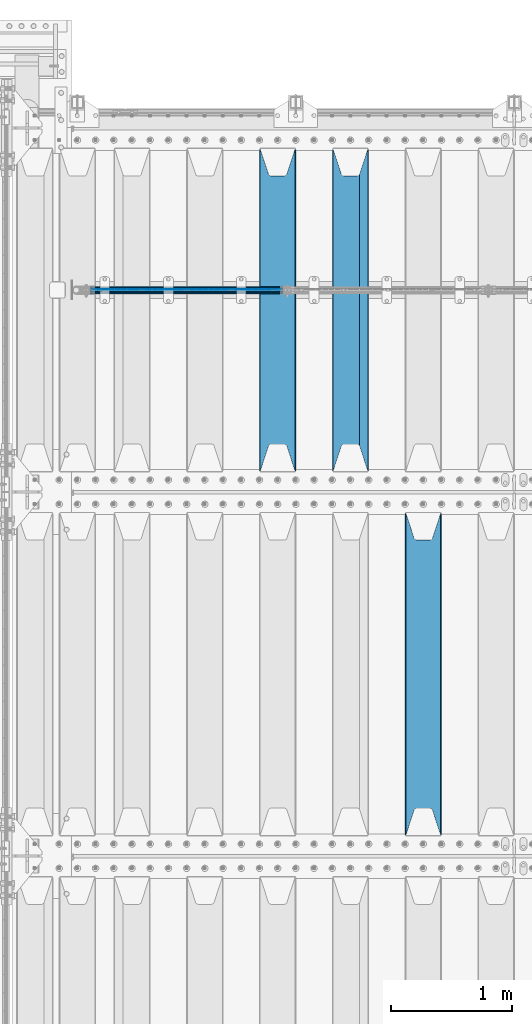
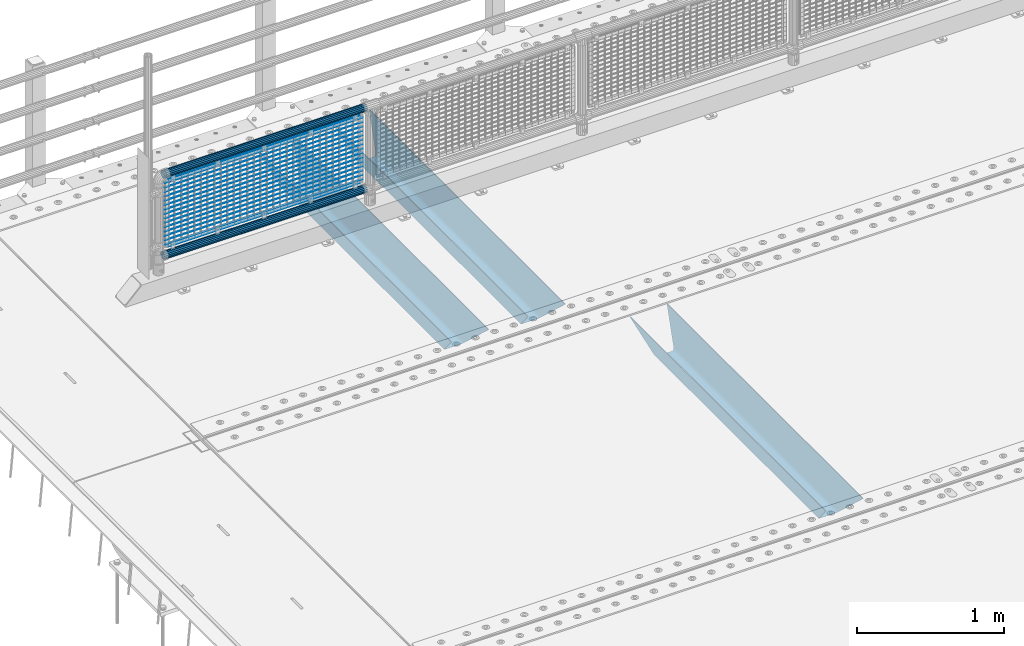
# One storey, part 114 of 240: 22 beams.
"""IFC2X3 building model written with IfcOpenShell, lengths in millimetres."""

from ifc_helpers import new_model, si_unit, frame, origin_with_axes, place, context, subcontext, project, spatial, faceted_brep, material, type_object, element, save


model = new_model("IFC2X3")

# Units and contexts
model_context = context("Model", 3, precision=1e-05, world=origin_with_axes())
body_context = subcontext(model_context, "Body", "Model", "MODEL_VIEW")
ifc_project = project(units=[si_unit("LENGTHUNIT", "METRE", prefix="MILLI"), si_unit("AREAUNIT", "SQUARE_METRE"), si_unit("VOLUMEUNIT", "CUBIC_METRE"), si_unit("MASSUNIT", "GRAM", prefix="KILO"), si_unit("TIMEUNIT", "SECOND"), si_unit("PLANEANGLEUNIT", "RADIAN"), si_unit("SOLIDANGLEUNIT", "STERADIAN"), si_unit("THERMODYNAMICTEMPERATUREUNIT", "DEGREE_CELSIUS"), si_unit("LUMINOUSINTENSITYUNIT", "LUMEN")], contexts=[model_context])

# Site, building, storey
site_placement = place(None, origin_with_axes())
site = spatial("IfcSite", under=ifc_project, at=site_placement, CompositionType="ELEMENT")
building_placement = place(site_placement, origin_with_axes())
building = spatial("IfcBuilding", under=site, at=building_placement, Name="Standard", CompositionType="ELEMENT")
storey_placement = place(building_placement, origin_with_axes())
storey = spatial("IfcBuildingStorey", under=building, at=storey_placement, Name="Undefined", CompositionType="ELEMENT", Elevation=0.0)

# Beams
ifc_material_1 = material(Name="STEEL/S355N")
beam_type_1 = type_object("IfcBeamType", PredefinedType="NOTDEFINED")
beam_1_placement = place(storey_placement, frame((45850.0, 30175.0, -115.0), z_axis=(0.0, 0.0, 1.0), x_axis=(0.0, 1.0, 0.0)))
element("IfcBeam", 1, at=beam_1_placement, inside=storey, type_object=beam_type_1, material=ifc_material_1, context=body_context, shape_type="Brep", body=[
    faceted_brep([(0.0, 150.0, 115.0), (0.0, 143.690000000002, 115.0), (2650.00000000297, 143.690000000002, 115.0), (2650.00000000297, 150.0, 115.0), (2650.00000000297, 142.059565218406, 110.000000003094), (2650.00000000297, 148.369565218403, 110.000000003094), (2441.90079219209, -80.1103600731149, -98.0992078077845), (2437.7588105432, -77.5672621345584, -102.241189456673), (2434.06523489747, -74.4080125315522, -105.934765102404), (2430.9108609509, -70.7102721255724, -109.089139048974), (2428.37322971128, -66.5649389910031, -111.626770288588), (2426.51472138055, -62.0739139532889, -113.485278619323), (2425.38102192092, -57.3475956567636, -114.618978078955), (2424.99999999987, -52.5021667386536, -115.0), (2424.99999999987, 52.5021667386536, -115.0), (2425.38102192092, 57.3475956567636, -114.618978078955), (2426.51472138055, 62.0739139532889, -113.485278619323), (2428.37322971128, 66.5649389910031, -111.626770288588), (2430.9108609509, 70.7102721255724, -109.089139048974), (2434.06523489747, 74.4080125315522, -105.934765102404), (2437.7588105432, 77.5672621345584, -102.241189456673), (2441.90079219209, 80.1103600731149, -98.0992078077846), (2446.38936140512, 81.9747917625791, -93.6106385947584), (2448.2494850041, 76.2713538057287, -91.7505149957729), (2444.62967112263, 74.76777986261, -95.3703288772456), (2441.28936334127, 72.7168944282894, -98.710636658607), (2438.31067330439, 70.1691124903809, -101.689326695487), (2435.76682334748, 67.1870637758839, -104.233176652398), (2433.72034654134, 63.8440531834931, -106.279653458539), (2432.22154950042, 60.2222587982324, -107.778450499454), (2431.30727574265, 56.4107117849126, -108.692724257221), (2430.99999999987, 52.5031078186876, -109.0), (2430.99999999987, -52.5031078186876, -109.0), (2431.30727574265, -56.4107117849126, -108.692724257221), (2432.22154950042, -60.2222587982324, -107.778450499454), (2433.72034654134, -63.8440531834931, -106.279653458539), (2435.76682334748, -67.1870637758839, -104.233176652398), (2438.31067330439, -70.1691124903809, -101.689326695487), (2441.28936334127, -72.7168944282894, -98.7106366586071), (2444.62967112263, -74.76777986261, -95.3703288772457), (2448.2494850041, -76.2713538057287, -91.7505149957729), (2650.00000000297, -142.059565218406, 110.000000003094), (2650.00000000297, -148.369565218403, 110.000000003094), (2446.38936140512, -81.9747917625791, -93.6106385947584), (2650.00000000297, -143.690000000002, 115.0), (2650.00000000297, -150.0, 115.0), (0.0, -143.690000000002, 115.0), (0.0, -150.0, 115.0), (0.0, -148.369565218258, 110.000000002667), (203.610638597427, -81.9747917625791, -93.6106385947584), (208.09920781045, -80.1103600731149, -98.0992078077845), (212.241189459342, -77.5672621345584, -102.241189456673), (215.93476510507, -74.4080125315522, -105.934765102404), (219.089139051641, -70.7102721255724, -109.089139048974), (221.626770291256, -66.5649389910031, -111.626770288588), (223.485278621989, -62.0739139532889, -113.485278619323), (224.618978081624, -57.3475956567636, -114.618978078955), (225.000000002663, -52.5021667386536, -115.0), (225.000000002663, 52.5021667386536, -115.0), (224.618978081624, 57.3475956567636, -114.618978078955), (223.485278621989, 62.0739139532889, -113.485278619323), (221.626770291256, 66.5649389910031, -111.626770288588), (219.089139051641, 70.7102721255724, -109.089139048974), (215.93476510507, 74.4080125315522, -105.934765102404), (212.241189459342, 77.5672621345584, -102.241189456673), (208.09920781045, 80.1103600731149, -98.0992078077846), (203.610638597427, 81.9747917625791, -93.6106385947584), (0.0, 148.369565218258, 110.000000002667), (0.0, 142.05956521826, 110.000000002667), (201.750514998439, 76.2713538057287, -91.7505149957729), (205.370328879908, 74.76777986261, -95.3703288772456), (208.710636661275, 72.7168944282894, -98.710636658607), (211.689326698153, 70.1691124903809, -101.689326695487), (214.233176655063, 67.1870637758839, -104.233176652398), (216.279653461206, 63.8440531834931, -106.279653458539), (217.778450502123, 60.2222587982324, -107.778450499454), (218.692724259887, 56.4107117849126, -108.692724257221), (219.000000002667, 52.5031078186876, -109.0), (219.000000002667, -52.5031078186876, -109.0), (218.692724259887, -56.4107117849126, -108.692724257221), (217.778450502123, -60.2222587982324, -107.778450499454), (216.279653461206, -63.8440531834931, -106.279653458539), (214.233176655063, -67.1870637758839, -104.233176652398), (211.689326698153, -70.1691124903809, -101.689326695487), (208.710636661275, -72.7168944282894, -98.7106366586071), (205.370328879915, -74.76777986261, -95.3703288772457), (201.750514998439, -76.2713538057287, -91.7505149957729), (0.0, -142.05956521826, 110.000000002667)], [[[0, 1, 2, 3]], [[3, 2, 4, 5]], [[6, 7, 8, 9, 10, 11, 12, 13, 14, 15, 16, 17, 18, 19, 20, 21, 22, 5, 4, 23, 24, 25, 26, 27, 28, 29, 30, 31, 32, 33, 34, 35, 36, 37, 38, 39, 40, 41, 42, 43]], [[44, 45, 42, 41]], [[46, 47, 45, 44]], [[43, 42, 45, 47, 48, 49]], [[6, 43, 49, 50]], [[7, 6, 50, 51]], [[8, 7, 51, 52]], [[9, 8, 52, 53]], [[10, 9, 53, 54]], [[11, 10, 54, 55]], [[12, 11, 55, 56]], [[13, 12, 56, 57]], [[14, 13, 57, 58]], [[15, 14, 58, 59]], [[16, 15, 59, 60]], [[17, 16, 60, 61]], [[18, 17, 61, 62]], [[19, 18, 62, 63]], [[20, 19, 63, 64]], [[21, 20, 64, 65]], [[22, 21, 65, 66]], [[0, 3, 5, 22, 66, 67]], [[1, 0, 67, 68]], [[23, 4, 2, 1, 68, 69]], [[24, 23, 69, 70]], [[25, 24, 70, 71]], [[26, 25, 71, 72]], [[27, 26, 72, 73]], [[28, 27, 73, 74]], [[29, 28, 74, 75]], [[30, 29, 75, 76]], [[31, 30, 76, 77]], [[32, 31, 77, 78]], [[33, 32, 78, 79]], [[34, 33, 79, 80]], [[35, 34, 80, 81]], [[36, 35, 81, 82]], [[37, 36, 82, 83]], [[38, 37, 83, 84]], [[39, 38, 84, 85]], [[40, 39, 85, 86]], [[46, 44, 41, 40, 86, 87]], [[47, 46, 87, 48]], [[86, 85, 84, 83, 82, 81, 80, 79, 78, 77, 76, 75, 74, 73, 72, 71, 70, 69, 68, 67, 66, 65, 64, 63, 62, 61, 60, 59, 58, 57, 56, 55, 54, 53, 52, 51, 50, 49, 48, 87]]]),
])
beam_2_placement = place(storey_placement, frame((45250.0, 33175.0, -115.0), z_axis=(0.0, 0.0, 1.0), x_axis=(0.0, 1.0, 0.0)))
element("IfcBeam", 2, at=beam_2_placement, inside=storey, type_object=beam_type_1, material=ifc_material_1, context=body_context, shape_type="Brep", body=[
    faceted_brep([(0.0, 150.0, 115.0), (0.0, 143.690000000002, 115.0), (2650.00000000297, 143.690000000002, 115.0), (2650.00000000297, 150.0, 115.0), (2650.00000000297, 142.059565218406, 110.000000003094), (2650.00000000297, 148.369565218403, 110.000000003094), (2441.90079219209, -80.1103600731149, -98.0992078077845), (2437.7588105432, -77.5672621345584, -102.241189456673), (2434.06523489747, -74.4080125315522, -105.934765102404), (2430.9108609509, -70.7102721255724, -109.089139048974), (2428.37322971128, -66.5649389910031, -111.626770288588), (2426.51472138055, -62.0739139532889, -113.485278619323), (2425.38102192092, -57.3475956567636, -114.618978078955), (2424.99999999987, -52.5021667386536, -115.0), (2424.99999999987, 52.5021667386536, -115.0), (2425.38102192092, 57.3475956567636, -114.618978078955), (2426.51472138055, 62.0739139532889, -113.485278619323), (2428.37322971128, 66.5649389910031, -111.626770288588), (2430.9108609509, 70.7102721255724, -109.089139048974), (2434.06523489747, 74.4080125315522, -105.934765102404), (2437.7588105432, 77.5672621345584, -102.241189456673), (2441.90079219209, 80.1103600731149, -98.0992078077846), (2446.38936140512, 81.9747917625791, -93.6106385947584), (2448.2494850041, 76.2713538057287, -91.7505149957729), (2444.62967112263, 74.76777986261, -95.3703288772456), (2441.28936334127, 72.7168944282894, -98.710636658607), (2438.31067330439, 70.1691124903809, -101.689326695487), (2435.76682334748, 67.1870637758839, -104.233176652398), (2433.72034654134, 63.8440531834931, -106.279653458539), (2432.22154950042, 60.2222587982324, -107.778450499454), (2431.30727574265, 56.4107117849126, -108.692724257221), (2430.99999999987, 52.5031078186876, -109.0), (2430.99999999987, -52.5031078186876, -109.0), (2431.30727574265, -56.4107117849126, -108.692724257221), (2432.22154950042, -60.2222587982324, -107.778450499454), (2433.72034654134, -63.8440531834931, -106.279653458539), (2435.76682334748, -67.1870637758839, -104.233176652398), (2438.31067330439, -70.1691124903809, -101.689326695487), (2441.28936334127, -72.7168944282894, -98.7106366586071), (2444.62967112263, -74.76777986261, -95.3703288772457), (2448.2494850041, -76.2713538057287, -91.7505149957729), (2650.00000000297, -142.059565218406, 110.000000003094), (2650.00000000297, -148.369565218403, 110.000000003094), (2446.38936140512, -81.9747917625791, -93.6106385947584), (2650.00000000297, -143.690000000002, 115.0), (2650.00000000297, -150.0, 115.0), (0.0, -143.690000000002, 115.0), (0.0, -150.0, 115.0), (0.0, -148.369565218258, 110.000000002667), (203.610638597427, -81.9747917625791, -93.6106385947584), (208.09920781045, -80.1103600731149, -98.0992078077845), (212.241189459342, -77.5672621345584, -102.241189456673), (215.93476510507, -74.4080125315522, -105.934765102404), (219.089139051641, -70.7102721255724, -109.089139048974), (221.626770291256, -66.5649389910031, -111.626770288588), (223.485278621989, -62.0739139532889, -113.485278619323), (224.618978081624, -57.3475956567636, -114.618978078955), (225.000000002663, -52.5021667386536, -115.0), (225.000000002663, 52.5021667386536, -115.0), (224.618978081624, 57.3475956567636, -114.618978078955), (223.485278621989, 62.0739139532889, -113.485278619323), (221.626770291256, 66.5649389910031, -111.626770288588), (219.089139051641, 70.7102721255724, -109.089139048974), (215.93476510507, 74.4080125315522, -105.934765102404), (212.241189459342, 77.5672621345584, -102.241189456673), (208.09920781045, 80.1103600731149, -98.0992078077846), (203.610638597427, 81.9747917625791, -93.6106385947584), (0.0, 148.369565218258, 110.000000002667), (0.0, 142.05956521826, 110.000000002667), (201.750514998439, 76.2713538057287, -91.7505149957729), (205.370328879908, 74.76777986261, -95.3703288772456), (208.710636661275, 72.7168944282894, -98.710636658607), (211.689326698153, 70.1691124903809, -101.689326695487), (214.233176655063, 67.1870637758839, -104.233176652398), (216.279653461206, 63.8440531834931, -106.279653458539), (217.778450502123, 60.2222587982324, -107.778450499454), (218.692724259887, 56.4107117849126, -108.692724257221), (219.000000002667, 52.5031078186876, -109.0), (219.000000002667, -52.5031078186876, -109.0), (218.692724259887, -56.4107117849126, -108.692724257221), (217.778450502123, -60.2222587982324, -107.778450499454), (216.279653461206, -63.8440531834931, -106.279653458539), (214.233176655063, -67.1870637758839, -104.233176652398), (211.689326698153, -70.1691124903809, -101.689326695487), (208.710636661275, -72.7168944282894, -98.7106366586071), (205.370328879915, -74.76777986261, -95.3703288772457), (201.750514998439, -76.2713538057287, -91.7505149957729), (0.0, -142.05956521826, 110.000000002667)], [[[0, 1, 2, 3]], [[3, 2, 4, 5]], [[6, 7, 8, 9, 10, 11, 12, 13, 14, 15, 16, 17, 18, 19, 20, 21, 22, 5, 4, 23, 24, 25, 26, 27, 28, 29, 30, 31, 32, 33, 34, 35, 36, 37, 38, 39, 40, 41, 42, 43]], [[44, 45, 42, 41]], [[46, 47, 45, 44]], [[43, 42, 45, 47, 48, 49]], [[6, 43, 49, 50]], [[7, 6, 50, 51]], [[8, 7, 51, 52]], [[9, 8, 52, 53]], [[10, 9, 53, 54]], [[11, 10, 54, 55]], [[12, 11, 55, 56]], [[13, 12, 56, 57]], [[14, 13, 57, 58]], [[15, 14, 58, 59]], [[16, 15, 59, 60]], [[17, 16, 60, 61]], [[18, 17, 61, 62]], [[19, 18, 62, 63]], [[20, 19, 63, 64]], [[21, 20, 64, 65]], [[22, 21, 65, 66]], [[0, 3, 5, 22, 66, 67]], [[1, 0, 67, 68]], [[23, 4, 2, 1, 68, 69]], [[24, 23, 69, 70]], [[25, 24, 70, 71]], [[26, 25, 71, 72]], [[27, 26, 72, 73]], [[28, 27, 73, 74]], [[29, 28, 74, 75]], [[30, 29, 75, 76]], [[31, 30, 76, 77]], [[32, 31, 77, 78]], [[33, 32, 78, 79]], [[34, 33, 79, 80]], [[35, 34, 80, 81]], [[36, 35, 81, 82]], [[37, 36, 82, 83]], [[38, 37, 83, 84]], [[39, 38, 84, 85]], [[40, 39, 85, 86]], [[46, 44, 41, 40, 86, 87]], [[47, 46, 87, 48]], [[86, 85, 84, 83, 82, 81, 80, 79, 78, 77, 76, 75, 74, 73, 72, 71, 70, 69, 68, 67, 66, 65, 64, 63, 62, 61, 60, 59, 58, 57, 56, 55, 54, 53, 52, 51, 50, 49, 48, 87]]]),
])
beam_3_placement = place(storey_placement, frame((44650.0, 33175.0, -115.0), z_axis=(0.0, 0.0, 1.0), x_axis=(0.0, 1.0, 0.0)))
element("IfcBeam", 3, at=beam_3_placement, inside=storey, type_object=beam_type_1, material=ifc_material_1, context=body_context, shape_type="Brep", body=[
    faceted_brep([(0.0, 150.0, 115.0), (0.0, 143.690000000002, 115.0), (2650.00000000297, 143.690000000002, 115.0), (2650.00000000297, 150.0, 115.0), (2650.00000000297, 142.059565218406, 110.000000003094), (2650.00000000297, 148.369565218403, 110.000000003094), (2441.90079219209, -80.1103600731149, -98.0992078077845), (2437.7588105432, -77.5672621345584, -102.241189456673), (2434.06523489747, -74.4080125315522, -105.934765102404), (2430.9108609509, -70.7102721255724, -109.089139048974), (2428.37322971128, -66.5649389910031, -111.626770288588), (2426.51472138055, -62.0739139532889, -113.485278619323), (2425.38102192092, -57.3475956567636, -114.618978078955), (2424.99999999987, -52.5021667386536, -115.0), (2424.99999999987, 52.5021667386536, -115.0), (2425.38102192092, 57.3475956567636, -114.618978078955), (2426.51472138055, 62.0739139532889, -113.485278619323), (2428.37322971128, 66.5649389910031, -111.626770288588), (2430.9108609509, 70.7102721255724, -109.089139048974), (2434.06523489747, 74.4080125315522, -105.934765102404), (2437.7588105432, 77.5672621345584, -102.241189456673), (2441.90079219209, 80.1103600731149, -98.0992078077846), (2446.38936140512, 81.9747917625791, -93.6106385947584), (2448.2494850041, 76.2713538057287, -91.7505149957729), (2444.62967112263, 74.76777986261, -95.3703288772456), (2441.28936334127, 72.7168944282894, -98.710636658607), (2438.31067330439, 70.1691124903809, -101.689326695487), (2435.76682334748, 67.1870637758839, -104.233176652398), (2433.72034654134, 63.8440531834931, -106.279653458539), (2432.22154950042, 60.2222587982324, -107.778450499454), (2431.30727574265, 56.4107117849126, -108.692724257221), (2430.99999999987, 52.5031078186876, -109.0), (2430.99999999987, -52.5031078186876, -109.0), (2431.30727574265, -56.4107117849126, -108.692724257221), (2432.22154950042, -60.2222587982324, -107.778450499454), (2433.72034654134, -63.8440531834931, -106.279653458539), (2435.76682334748, -67.1870637758839, -104.233176652398), (2438.31067330439, -70.1691124903809, -101.689326695487), (2441.28936334127, -72.7168944282894, -98.7106366586071), (2444.62967112263, -74.76777986261, -95.3703288772457), (2448.2494850041, -76.2713538057287, -91.7505149957729), (2650.00000000297, -142.059565218406, 110.000000003094), (2650.00000000297, -148.369565218403, 110.000000003094), (2446.38936140512, -81.9747917625791, -93.6106385947584), (2650.00000000297, -143.690000000002, 115.0), (2650.00000000297, -150.0, 115.0), (0.0, -143.690000000002, 115.0), (0.0, -150.0, 115.0), (0.0, -148.369565218258, 110.000000002667), (203.610638597427, -81.9747917625791, -93.6106385947584), (208.09920781045, -80.1103600731149, -98.0992078077845), (212.241189459342, -77.5672621345584, -102.241189456673), (215.93476510507, -74.4080125315522, -105.934765102404), (219.089139051641, -70.7102721255724, -109.089139048974), (221.626770291256, -66.5649389910031, -111.626770288588), (223.485278621989, -62.0739139532889, -113.485278619323), (224.618978081624, -57.3475956567636, -114.618978078955), (225.000000002663, -52.5021667386536, -115.0), (225.000000002663, 52.5021667386536, -115.0), (224.618978081624, 57.3475956567636, -114.618978078955), (223.485278621989, 62.0739139532889, -113.485278619323), (221.626770291256, 66.5649389910031, -111.626770288588), (219.089139051641, 70.7102721255724, -109.089139048974), (215.93476510507, 74.4080125315522, -105.934765102404), (212.241189459342, 77.5672621345584, -102.241189456673), (208.09920781045, 80.1103600731149, -98.0992078077846), (203.610638597427, 81.9747917625791, -93.6106385947584), (0.0, 148.369565218258, 110.000000002667), (0.0, 142.05956521826, 110.000000002667), (201.750514998439, 76.2713538057287, -91.7505149957729), (205.370328879908, 74.76777986261, -95.3703288772456), (208.710636661275, 72.7168944282894, -98.710636658607), (211.689326698153, 70.1691124903809, -101.689326695487), (214.233176655063, 67.1870637758839, -104.233176652398), (216.279653461206, 63.8440531834931, -106.279653458539), (217.778450502123, 60.2222587982324, -107.778450499454), (218.692724259887, 56.4107117849126, -108.692724257221), (219.000000002667, 52.5031078186876, -109.0), (219.000000002667, -52.5031078186876, -109.0), (218.692724259887, -56.4107117849126, -108.692724257221), (217.778450502123, -60.2222587982324, -107.778450499454), (216.279653461206, -63.8440531834931, -106.279653458539), (214.233176655063, -67.1870637758839, -104.233176652398), (211.689326698153, -70.1691124903809, -101.689326695487), (208.710636661275, -72.7168944282894, -98.7106366586071), (205.370328879915, -74.76777986261, -95.3703288772457), (201.750514998439, -76.2713538057287, -91.7505149957729), (0.0, -142.05956521826, 110.000000002667)], [[[0, 1, 2, 3]], [[3, 2, 4, 5]], [[6, 7, 8, 9, 10, 11, 12, 13, 14, 15, 16, 17, 18, 19, 20, 21, 22, 5, 4, 23, 24, 25, 26, 27, 28, 29, 30, 31, 32, 33, 34, 35, 36, 37, 38, 39, 40, 41, 42, 43]], [[44, 45, 42, 41]], [[46, 47, 45, 44]], [[43, 42, 45, 47, 48, 49]], [[6, 43, 49, 50]], [[7, 6, 50, 51]], [[8, 7, 51, 52]], [[9, 8, 52, 53]], [[10, 9, 53, 54]], [[11, 10, 54, 55]], [[12, 11, 55, 56]], [[13, 12, 56, 57]], [[14, 13, 57, 58]], [[15, 14, 58, 59]], [[16, 15, 59, 60]], [[17, 16, 60, 61]], [[18, 17, 61, 62]], [[19, 18, 62, 63]], [[20, 19, 63, 64]], [[21, 20, 64, 65]], [[22, 21, 65, 66]], [[0, 3, 5, 22, 66, 67]], [[1, 0, 67, 68]], [[23, 4, 2, 1, 68, 69]], [[24, 23, 69, 70]], [[25, 24, 70, 71]], [[26, 25, 71, 72]], [[27, 26, 72, 73]], [[28, 27, 73, 74]], [[29, 28, 74, 75]], [[30, 29, 75, 76]], [[31, 30, 76, 77]], [[32, 31, 77, 78]], [[33, 32, 78, 79]], [[34, 33, 79, 80]], [[35, 34, 80, 81]], [[36, 35, 81, 82]], [[37, 36, 82, 83]], [[38, 37, 83, 84]], [[39, 38, 84, 85]], [[40, 39, 85, 86]], [[46, 44, 41, 40, 86, 87]], [[47, 46, 87, 48]], [[86, 85, 84, 83, 82, 81, 80, 79, 78, 77, 76, 75, 74, 73, 72, 71, 70, 69, 68, 67, 66, 65, 64, 63, 62, 61, 60, 59, 58, 57, 56, 55, 54, 53, 52, 51, 50, 49, 48, 87]]]),
])
ifc_material_2 = material(Name="Misc_Undefined")
beam_type_2 = type_object("IfcBeamType", Name="D3", PredefinedType="NOTDEFINED")
for number, where, z_axis, x_axis in (
    (4, (43126.0, 34670.5, 851.596999999999), (0.0, 0.0, 1.0), (1.0, 0.0, 0.0)),
    (5, (43126.0, 34670.5, 669.452), (0.0, 0.0, 1.0), (1.0, 0.0, 0.0)),
    (6, (43126.0, 34670.5, 523.736), (0.0, 0.0, 1.0), (1.0, 0.0, 0.0)),
    (7, (43126.0, 34670.5, 487.307), (0.0, 0.0, 1.0), (1.0, 0.0, 0.0)),
    (8, (43126.0, 34670.5, 705.881), (0.0, 0.0, 1.0), (1.0, 0.0, 0.0)),
    (9, (43126.0, 34670.5, 596.594), (0.0, 0.0, 1.0), (1.0, 0.0, 0.0)),
    (10, (43126.0, 34670.5, 450.878), (0.0, 0.0, 1.0), (1.0, 0.0, 0.0)),
    (11, (43126.0, 34670.5, 815.167999999999), (0.0, 0.0, 1.0), (1.0, 0.0, 0.0)),
    (12, (43126.0, 34670.5, 888.025999999999), (0.0, 0.0, 1.0), (1.0, 0.0, 0.0)),
    (13, (43126.0, 34670.5, 778.738999999999), (0.0, 0.0, 1.0), (1.0, 0.0, 0.0)),
    (14, (43126.0, 34670.5, 742.309999999999), (0.0, 0.0, 1.0), (1.0, 0.0, 0.0)),
    (15, (43126.0, 34670.5, 633.023), (0.0, 0.0, 1.0), (1.0, 0.0, 0.0)),
    (16, (43126.0, 34670.5, 560.165), (0.0, 0.0, 1.0), (1.0, 0.0, 0.0)),
    (17, (43126.0, 34670.5, 414.449), (0.0, 0.0, 1.0), (1.0, 0.0, 0.0)),
):
    element("IfcBeam", number, at=place(storey_placement, frame(where, z_axis=z_axis, x_axis=x_axis)), inside=storey, type_object=beam_type_2, material=ifc_material_2, ObjectType="D3", context=body_context, shape_type="Brep", body=[
        faceted_brep([(-7.27595761418343e-12, -1.49999999999272, 0.0), (-7.27595761418343e-12, -0.749999999992724, -1.29903810567669), (1548.0, -0.75, -1.29903810567669), (1548.0, -1.5, 0.0), (0.0, 0.750000000007276, -1.29903810567669), (1548.0, 0.75, -1.29903810567669), (0.0, 1.50000000000728, 0.0), (1548.0, 1.5, 0.0), (0.0, 0.750000000007276, 1.29903810567669), (1548.0, 0.75, 1.29903810567669), (-7.27595761418343e-12, -0.749999999992724, 1.29903810567669), (1548.0, -0.75, 1.29903810567669)], [[[0, 1, 2, 3]], [[1, 4, 5, 2]], [[4, 6, 7, 5]], [[6, 8, 9, 7]], [[8, 10, 11, 9]], [[10, 0, 3, 11]], [[5, 7, 9, 11, 3, 2]], [[10, 8, 6, 4, 1, 0]]]),
    ])
beam_4_placement = place(storey_placement, frame((43151.0, 34670.5, 353.02), z_axis=(0.0, 0.0, 1.0), x_axis=(1.0, 0.0, 0.0)))
element("IfcBeam", 18, at=beam_4_placement, inside=storey, type_object=beam_type_2, material=ifc_material_2, ObjectType="D3", context=body_context, shape_type="Brep", body=[
    faceted_brep([(-7.27595761418343e-12, -1.49999999999272, 0.0), (-7.27595761418343e-12, -0.749999999992724, -1.29903810567669), (1498.0, -0.75, -1.29903810567669), (1498.0, -1.5, 0.0), (0.0, 0.750000000007276, -1.29903810567669), (1498.0, 0.75, -1.29903810567663), (0.0, 1.50000000000728, 0.0), (1498.0, 1.5, 0.0), (0.0, 0.750000000007276, 1.29903810567669), (1498.0, 0.75, 1.29903810567669), (-7.27595761418343e-12, -0.749999999992724, 1.29903810567669), (1498.0, -0.75, 1.29903810567669)], [[[0, 1, 2, 3]], [[1, 4, 5, 2]], [[4, 6, 7, 5]], [[6, 8, 9, 7]], [[8, 10, 11, 9]], [[10, 0, 3, 11]], [[5, 7, 9, 11, 3, 2]], [[10, 8, 6, 4, 1, 0]]]),
])
beam_5_placement = place(storey_placement, frame((43126.0, 34670.5, 378.02), z_axis=(0.0, 0.0, 1.0), x_axis=(1.0, 0.0, 0.0)))
element("IfcBeam", 19, at=beam_5_placement, inside=storey, type_object=beam_type_2, material=ifc_material_2, ObjectType="D3", context=body_context, shape_type="Brep", body=[
    faceted_brep([(-7.27595761418343e-12, -1.49999999999272, 0.0), (-7.27595761418343e-12, -0.749999999992724, -1.29903810567669), (1548.0, -0.75, -1.29903810567669), (1548.0, -1.5, 0.0), (0.0, 0.750000000007276, -1.29903810567669), (1548.0, 0.75, -1.29903810567669), (0.0, 1.50000000000728, 0.0), (1548.0, 1.5, 0.0), (0.0, 0.750000000007276, 1.29903810567669), (1548.0, 0.75, 1.29903810567669), (-7.27595761418343e-12, -0.749999999992724, 1.29903810567669), (1548.0, -0.75, 1.29903810567669)], [[[0, 1, 2, 3]], [[1, 4, 5, 2]], [[4, 6, 7, 5]], [[6, 8, 9, 7]], [[8, 10, 11, 9]], [[10, 0, 3, 11]], [[5, 7, 9, 11, 3, 2]], [[10, 8, 6, 4, 1, 0]]]),
])
beam_6_placement = place(storey_placement, frame((43151.0, 34670.5, 913.02), z_axis=(0.0, 0.0, 1.0), x_axis=(1.0, 0.0, 0.0)))
element("IfcBeam", 20, at=beam_6_placement, inside=storey, type_object=beam_type_2, material=ifc_material_2, ObjectType="D3", context=body_context, shape_type="Brep", body=[
    faceted_brep([(-7.27595761418343e-12, -1.49999999999272, 0.0), (-7.27595761418343e-12, -0.749999999992724, -1.29903810567669), (1498.0, -0.75, -1.29903810567669), (1498.0, -1.5, 0.0), (0.0, 0.750000000007276, -1.29903810567669), (1498.0, 0.75, -1.29903810567663), (0.0, 1.50000000000728, 0.0), (1498.0, 1.5, 0.0), (0.0, 0.750000000007276, 1.29903810567669), (1498.0, 0.75, 1.29903810567669), (-7.27595761418343e-12, -0.749999999992724, 1.29903810567669), (1498.0, -0.75, 1.29903810567669)], [[[0, 1, 2, 3]], [[1, 4, 5, 2]], [[4, 6, 7, 5]], [[6, 8, 9, 7]], [[8, 10, 11, 9]], [[10, 0, 3, 11]], [[5, 7, 9, 11, 3, 2]], [[10, 8, 6, 4, 1, 0]]]),
])
ifc_material_3 = material()
beam_type_3 = type_object("IfcBeamType", PredefinedType="NOTDEFINED")
beam_7_placement = place(storey_placement, frame((43105.85, 34664.5, 969.849999999999), z_axis=(0.0, 0.0, 1.0), x_axis=(1.0, 0.0, 0.0)))
element("IfcBeam", 21, at=beam_7_placement, inside=storey, type_object=beam_type_3, material=ifc_material_3, context=body_context, shape_type="Brep", body=[
    faceted_brep([(0.0, -25.3499999999985, 0.0), (0.0, -23.4203461491634, 9.70102501045767), (1588.0, -23.4203461491634, 9.70102501045506), (1588.0, -25.3499999999985, 0.0), (0.0, -17.9251569030821, 17.9251569030821), (1588.0, -17.9251569030821, 17.925156903079), (0.0, -9.70102501045767, 23.4203461491634), (1588.0, -9.70102501045767, 23.4203461491611), (0.0, 0.0, 25.3499999999985), (1588.0, 0.0, 25.35), (0.0, 9.70102501045767, 23.4203461491634), (1588.0, 9.70102501045767, 23.4203461491611), (0.0, 17.9251569030821, 17.9251569030821), (1588.0, 17.9251569030821, 17.925156903079), (0.0, 23.4203461491634, 9.70102501045767), (1588.0, 23.4203461491634, 9.70102501045506), (0.0, 25.3499999999985, 0.0), (1588.0, 25.3499999999985, 0.0), (0.0, 23.4203461491634, -9.70102501045767), (1588.0, 23.4203461491634, -9.70102501045506), (0.0, 17.9251569030821, -17.9251569030821), (1588.0, 17.9251569030821, -17.925156903079), (0.0, 9.70102501045767, -23.4203461491634), (1588.0, 9.70102501045767, -23.4203461491611), (0.0, 0.0, -25.3499999999985), (1588.0, 0.0, -25.35), (0.0, -9.70102501045767, -23.4203461491634), (1588.0, -9.70102501045767, -23.4203461491611), (0.0, -17.9251569030821, -17.9251569030821), (1588.0, -17.9251569030821, -17.925156903079), (0.0, -23.4203461491634, -9.70102501045767), (1588.0, -23.4203461491634, -9.70102501045506), (0.0, -30.1500000000015, 0.0), (0.0, -27.8549679052157, -11.5379054858058), (1588.0, -27.8549679052157, -11.5379054858075), (1588.0, -30.1500000000015, 0.0), (0.0, -21.3192694527752, -21.3192694527752), (1588.0, -21.3192694527752, -21.3192694527744), (0.0, -11.5379054858058, -27.8549679052157), (1588.0, -11.5379054858058, -27.8549679052153), (0.0, 0.0, -30.1500000000015), (1588.0, 0.0, -30.15), (0.0, 11.5379054858058, -27.8549679052157), (1588.0, 11.5379054858058, -27.8549679052153), (0.0, 21.3192694527752, -21.3192694527752), (1588.0, 21.3192694527752, -21.3192694527744), (0.0, 27.8549679052157, -11.5379054858058), (1588.0, 27.8549679052157, -11.5379054858074), (0.0, 30.1500000000015, 0.0), (1588.0, 30.1500000000015, 0.0), (0.0, 27.8549679052157, 11.5379054858058), (1588.0, 27.8549679052157, 11.5379054858074), (0.0, 21.3192694527752, 21.3192694527752), (1588.0, 21.3192694527752, 21.3192694527744), (0.0, 11.5379054858058, 27.8549679052157), (1588.0, 11.5379054858058, 27.8549679052153), (0.0, 0.0, 30.1500000000015), (1588.0, 0.0, 30.15), (0.0, -11.5379054858058, 27.8549679052157), (1588.0, -11.5379054858058, 27.8549679052153), (0.0, -21.3192694527752, 21.3192694527752), (1588.0, -21.3192694527752, 21.3192694527744), (0.0, -27.8549679052157, 11.5379054858058), (1588.0, -27.8549679052157, 11.5379054858074)], [[[0, 1, 2, 3]], [[1, 4, 5, 2]], [[4, 6, 7, 5]], [[6, 8, 9, 7]], [[8, 10, 11, 9]], [[10, 12, 13, 11]], [[12, 14, 15, 13]], [[14, 16, 17, 15]], [[16, 18, 19, 17]], [[18, 20, 21, 19]], [[20, 22, 23, 21]], [[22, 24, 25, 23]], [[24, 26, 27, 25]], [[26, 28, 29, 27]], [[28, 30, 31, 29]], [[30, 0, 3, 31]], [[32, 33, 34, 35]], [[33, 36, 37, 34]], [[36, 38, 39, 37]], [[38, 40, 41, 39]], [[40, 42, 43, 41]], [[42, 44, 45, 43]], [[44, 46, 47, 45]], [[46, 48, 49, 47]], [[48, 50, 51, 49]], [[50, 52, 53, 51]], [[52, 54, 55, 53]], [[54, 56, 57, 55]], [[56, 58, 59, 57]], [[58, 60, 61, 59]], [[60, 62, 63, 61]], [[62, 32, 35, 63]], [[37, 39, 41, 43, 45, 47, 49, 51, 53, 55, 57, 59, 61, 63, 35, 34], [5, 7, 9, 11, 13, 15, 17, 19, 21, 23, 25, 27, 29, 31, 3, 2]], [[62, 60, 58, 56, 54, 52, 50, 48, 46, 44, 42, 40, 38, 36, 33, 32], [30, 28, 26, 24, 22, 20, 18, 16, 14, 12, 10, 8, 6, 4, 1, 0]]]),
])
beam_8_placement = place(storey_placement, frame((43105.85, 34664.5, 298.170000000001), z_axis=(0.0, 0.0, 1.0), x_axis=(1.0, 0.0, 0.0)))
element("IfcBeam", 22, at=beam_8_placement, inside=storey, type_object=beam_type_3, material=ifc_material_3, context=body_context, shape_type="Brep", body=[
    faceted_brep([(0.0, -25.3499999999985, 0.0), (0.0, -23.4203461491634, 9.70102501045767), (1588.0, -23.4203461491634, 9.70102501045506), (1588.0, -25.3499999999985, 0.0), (0.0, -17.9251569030821, 17.9251569030821), (1588.0, -17.9251569030821, 17.925156903079), (0.0, -9.70102501045767, 23.4203461491634), (1588.0, -9.70102501045767, 23.4203461491611), (0.0, 0.0, 25.3499999999985), (1588.0, 0.0, 25.35), (0.0, 9.70102501045767, 23.4203461491634), (1588.0, 9.70102501045767, 23.4203461491611), (0.0, 17.9251569030821, 17.9251569030821), (1588.0, 17.9251569030821, 17.925156903079), (0.0, 23.4203461491634, 9.70102501045767), (1588.0, 23.4203461491634, 9.70102501045506), (0.0, 25.3499999999985, 0.0), (1588.0, 25.3499999999985, 0.0), (0.0, 23.4203461491634, -9.70102501045767), (1588.0, 23.4203461491634, -9.70102501045506), (0.0, 17.9251569030821, -17.9251569030821), (1588.0, 17.9251569030821, -17.925156903079), (0.0, 9.70102501045767, -23.4203461491634), (1588.0, 9.70102501045767, -23.4203461491611), (0.0, 0.0, -25.3499999999985), (1588.0, 0.0, -25.35), (0.0, -9.70102501045767, -23.4203461491634), (1588.0, -9.70102501045767, -23.4203461491611), (0.0, -17.9251569030821, -17.9251569030821), (1588.0, -17.9251569030821, -17.925156903079), (0.0, -23.4203461491634, -9.70102501045767), (1588.0, -23.4203461491634, -9.70102501045506), (0.0, -30.1500000000015, 0.0), (0.0, -27.8549679052157, -11.5379054858058), (1588.0, -27.8549679052157, -11.5379054858075), (1588.0, -30.1500000000015, 0.0), (0.0, -21.3192694527752, -21.3192694527752), (1588.0, -21.3192694527752, -21.3192694527744), (0.0, -11.5379054858058, -27.8549679052157), (1588.0, -11.5379054858058, -27.8549679052153), (0.0, 0.0, -30.1500000000015), (1588.0, 0.0, -30.15), (0.0, 11.5379054858058, -27.8549679052157), (1588.0, 11.5379054858058, -27.8549679052153), (0.0, 21.3192694527752, -21.3192694527752), (1588.0, 21.3192694527752, -21.3192694527744), (0.0, 27.8549679052157, -11.5379054858058), (1588.0, 27.8549679052157, -11.5379054858074), (0.0, 30.1500000000015, 0.0), (1588.0, 30.1500000000015, 0.0), (0.0, 27.8549679052157, 11.5379054858058), (1588.0, 27.8549679052157, 11.5379054858074), (0.0, 21.3192694527752, 21.3192694527752), (1588.0, 21.3192694527752, 21.3192694527744), (0.0, 11.5379054858058, 27.8549679052157), (1588.0, 11.5379054858058, 27.8549679052153), (0.0, 0.0, 30.1500000000015), (1588.0, 0.0, 30.15), (0.0, -11.5379054858058, 27.8549679052157), (1588.0, -11.5379054858058, 27.8549679052153), (0.0, -21.3192694527752, 21.3192694527752), (1588.0, -21.3192694527752, 21.3192694527744), (0.0, -27.8549679052157, 11.5379054858058), (1588.0, -27.8549679052157, 11.5379054858074)], [[[0, 1, 2, 3]], [[1, 4, 5, 2]], [[4, 6, 7, 5]], [[6, 8, 9, 7]], [[8, 10, 11, 9]], [[10, 12, 13, 11]], [[12, 14, 15, 13]], [[14, 16, 17, 15]], [[16, 18, 19, 17]], [[18, 20, 21, 19]], [[20, 22, 23, 21]], [[22, 24, 25, 23]], [[24, 26, 27, 25]], [[26, 28, 29, 27]], [[28, 30, 31, 29]], [[30, 0, 3, 31]], [[32, 33, 34, 35]], [[33, 36, 37, 34]], [[36, 38, 39, 37]], [[38, 40, 41, 39]], [[40, 42, 43, 41]], [[42, 44, 45, 43]], [[44, 46, 47, 45]], [[46, 48, 49, 47]], [[48, 50, 51, 49]], [[50, 52, 53, 51]], [[52, 54, 55, 53]], [[54, 56, 57, 55]], [[56, 58, 59, 57]], [[58, 60, 61, 59]], [[60, 62, 63, 61]], [[62, 32, 35, 63]], [[37, 39, 41, 43, 45, 47, 49, 51, 53, 55, 57, 59, 61, 63, 35, 34], [5, 7, 9, 11, 13, 15, 17, 19, 21, 23, 25, 27, 29, 31, 3, 2]], [[62, 60, 58, 56, 54, 52, 50, 48, 46, 44, 42, 40, 38, 36, 33, 32], [30, 28, 26, 24, 22, 20, 18, 16, 14, 12, 10, 8, 6, 4, 1, 0]]]),
])

save(model, "model.ifc")
